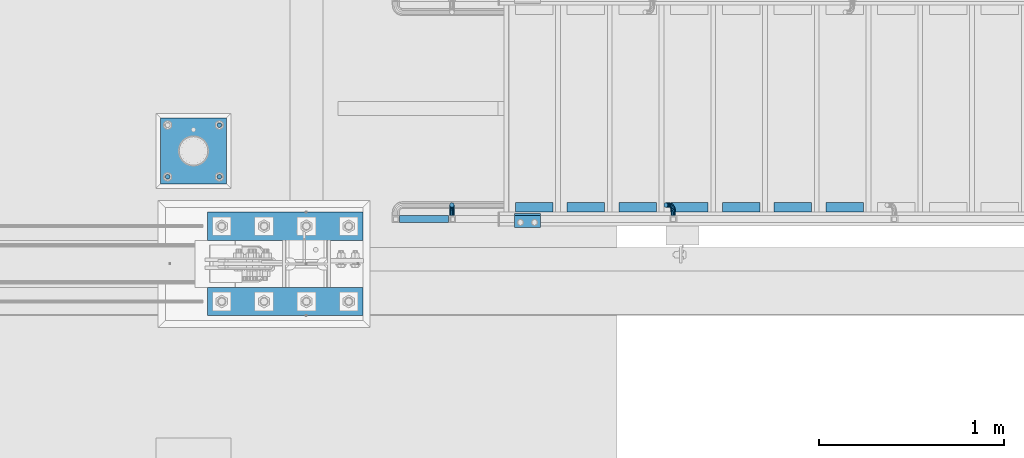
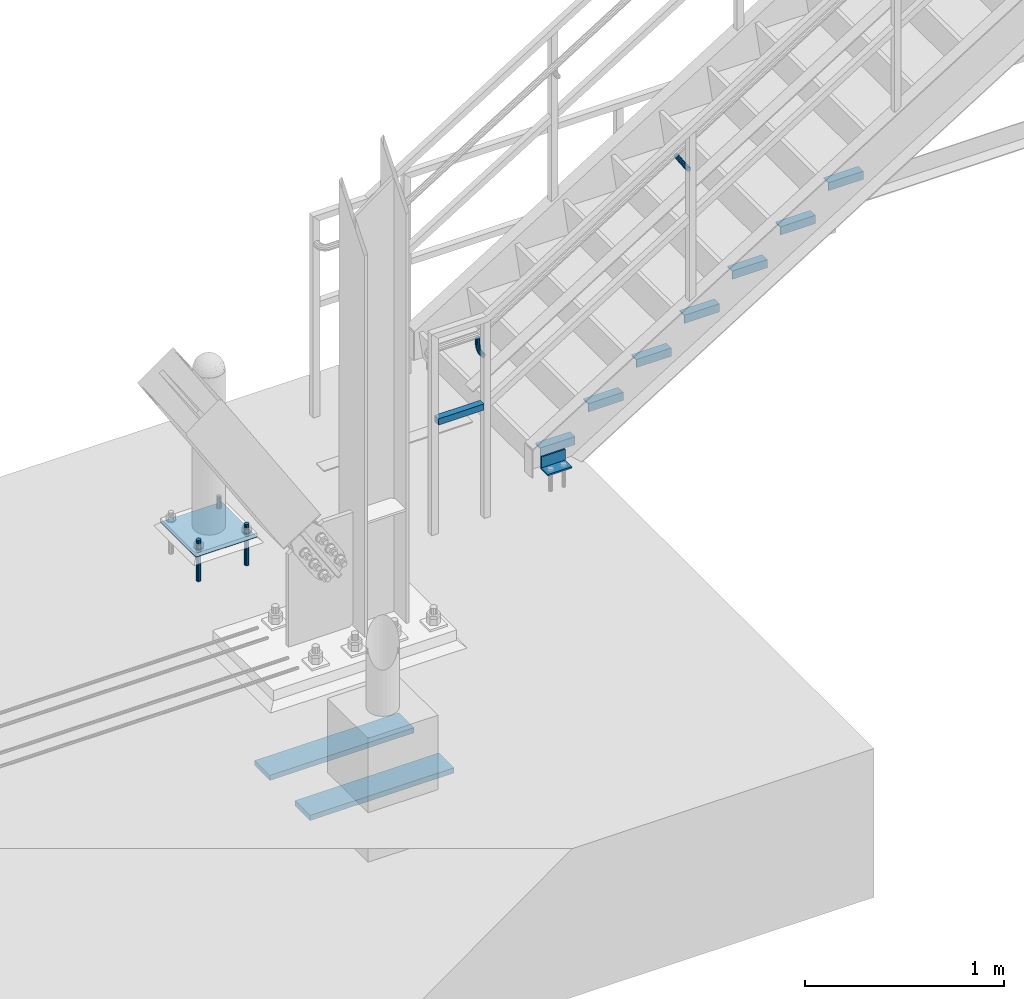
# One storey, part 2410 of 3843: 17 beams, 4 elements without a shape of their own.
"""IFC2X3 building model written with IfcOpenShell, lengths in millimetres."""

from ifc_helpers import new_model, si_unit, frame, origin_with_axes, place, context, subcontext, project, spatial, faceted_brep, material, type_object, element, aggregate, save


model = new_model("IFC2X3")

# Units and contexts
model_context = context("Model", 3, precision=1e-05, world=origin_with_axes())
body_context = subcontext(model_context, "Body", "Model", "MODEL_VIEW")
ifc_project = project(units=[si_unit("LENGTHUNIT", "METRE", prefix="MILLI"), si_unit("AREAUNIT", "SQUARE_METRE"), si_unit("VOLUMEUNIT", "CUBIC_METRE"), si_unit("MASSUNIT", "GRAM", prefix="KILO"), si_unit("TIMEUNIT", "SECOND"), si_unit("PLANEANGLEUNIT", "RADIAN"), si_unit("SOLIDANGLEUNIT", "STERADIAN"), si_unit("THERMODYNAMICTEMPERATUREUNIT", "DEGREE_CELSIUS"), si_unit("LUMINOUSINTENSITYUNIT", "LUMEN")], contexts=[model_context])

# Site, building, storey
site_placement = place(None, origin_with_axes())
site = spatial("IfcSite", under=ifc_project, at=site_placement, CompositionType="ELEMENT")
building_placement = place(site_placement, origin_with_axes())
building = spatial("IfcBuilding", under=site, at=building_placement, Name="Undefined", CompositionType="ELEMENT")
storey_placement = place(building_placement, origin_with_axes())
storey = spatial("IfcBuildingStorey", under=building, at=storey_placement, Name="Undefined", CompositionType="ELEMENT", Elevation=0.0)

# Assembly, beam
assembly_1_placement = place(storey_placement, origin_with_axes())
assembly_1 = element("IfcElementAssembly", 1, at=assembly_1_placement, inside=storey, Name="STAIR", AssemblyPlace="NOTDEFINED", PredefinedType="RIGID_FRAME")
ifc_material_1 = material(Name="STEEL/A572-50")
beam_type_1 = type_object("IfcBeamType", Name="L3X3X3/8", PredefinedType="NOTDEFINED")
beam_1_placement = place(assembly_1_placement, frame((31743.65, 89349.2625000009, 30518.1), z_axis=(0.0, -1.0, 0.0), x_axis=(-1.0, 0.0, 0.0)))
beam_1 = element("IfcBeam", 2, at=beam_1_placement, type_object=beam_type_1, material=ifc_material_1, Name="CLEAT", ObjectType="L3X3X3/8", context=body_context, shape_type="Brep", body=[
    faceted_brep([(0.0, 38.0999999999985, -38.0999999999985), (0.0, 38.0999999999985, 38.0999999999985), (139.699999999997, 38.0999999999985, 38.0999999999985), (139.699999999997, 38.0999999999985, -38.0999999999985), (0.0, 28.5750000000007, 38.0999999999985), (139.699999999997, 28.5750000000007, 38.0999999999985), (0.0, 28.5750000000007, -28.5750000000007), (139.699999999997, 28.5750000000007, -28.5750000000007), (0.0, -38.0999999999985, -28.5750000000007), (139.699999999997, -38.0999999999985, -28.5750000000007), (0.0, -38.0999999999985, -38.0999999999985), (139.699999999997, -38.0999999999985, -38.0999999999985)], [[[0, 1, 2, 3]], [[1, 4, 5, 2]], [[4, 6, 7, 5]], [[6, 8, 9, 7]], [[8, 10, 11, 9]], [[10, 0, 3, 11]], [[5, 7, 9, 11, 3, 2]], [[10, 8, 6, 4, 1, 0]]]),
])

# Assembly, beams
assembly_2_placement = place(storey_placement, origin_with_axes())
assembly_2 = element("IfcElementAssembly", 3, at=assembly_2_placement, inside=storey, Name="TEMPLATE", AssemblyPlace="NOTDEFINED", PredefinedType="RIGID_FRAME")
ifc_material_2 = material(Name="STEEL/316 SS")
beam_type_2 = type_object("IfcBeamType", PredefinedType="NOTDEFINED")
beam_2_placement = place(assembly_2_placement, frame((30010.1, 89585.8, 30581.6), z_axis=(1.0, 0.0, 0.0), x_axis=(0.0, 0.0, -1.0)))
beam_2 = element("IfcBeam", 4, at=beam_2_placement, type_object=beam_type_2, material=ifc_material_2, Name="ANCHOR_ROD", context=body_context, shape_type="Brep", body=[
    faceted_brep([(0.0, -12.6999999999971, 0.0), (0.0, -10.9985226280696, -6.34999999999854), (253.999, -10.9985226280696, -6.34999999999854), (253.999, -12.6999999999971, 0.0), (0.0, -6.35000000000582, -10.9985226280623), (253.999, -6.35000000000582, -10.9985226280623), (0.0, 0.0, -12.6999999999971), (253.999, 0.0, -12.6999999999971), (0.0, 6.35000000000582, -10.9985226280623), (253.999, 6.35000000000582, -10.9985226280623), (0.0, 10.9985226280696, -6.34999999999854), (253.999, 10.9985226280696, -6.34999999999854), (0.0, 12.6999999999971, 0.0), (253.999, 12.6999999999971, 0.0), (0.0, 10.9985226280696, 6.34999999999854), (253.999, 10.9985226280696, 6.34999999999854), (0.0, 6.35000000000582, 10.9985226280623), (253.999, 6.35000000000582, 10.9985226280623), (0.0, 0.0, 12.6999999999971), (253.999, 0.0, 12.6999999999971), (0.0, -6.35000000000582, 10.9985226280623), (253.999, -6.35000000000582, 10.9985226280623), (0.0, -10.9985226280696, 6.34999999999854), (253.999, -10.9985226280696, 6.34999999999854)], [[[0, 1, 2, 3]], [[1, 4, 5, 2]], [[4, 6, 7, 5]], [[6, 8, 9, 7]], [[8, 10, 11, 9]], [[10, 12, 13, 11]], [[12, 14, 15, 13]], [[14, 16, 17, 15]], [[16, 18, 19, 17]], [[18, 20, 21, 19]], [[20, 22, 23, 21]], [[22, 0, 3, 23]], [[5, 7, 9, 11, 13, 15, 17, 19, 21, 23, 3, 2]], [[22, 20, 18, 16, 14, 12, 10, 8, 6, 4, 1, 0]]]),
])
beam_3_placement = place(assembly_2_placement, frame((30010.1, 89865.2, 30581.6), z_axis=(-1.0, 0.0, 0.0), x_axis=(0.0, 0.0, -1.0)))
beam_3 = element("IfcBeam", 5, at=beam_3_placement, type_object=beam_type_2, material=ifc_material_2, Name="ANCHOR_ROD", context=body_context, shape_type="Brep", body=[
    faceted_brep([(0.0, -12.6999999999971, 0.0), (0.0, -10.9985226280696, -6.34999999999854), (253.999, -10.9985226280696, -6.34999999999854), (253.999, -12.6999999999971, 0.0), (0.0, -6.35000000000582, -10.9985226280623), (253.999, -6.35000000000582, -10.9985226280623), (0.0, 0.0, -12.6999999999971), (253.999, 0.0, -12.6999999999971), (0.0, 6.35000000000582, -10.9985226280623), (253.999, 6.35000000000582, -10.9985226280623), (0.0, 10.9985226280696, -6.34999999999854), (253.999, 10.9985226280696, -6.34999999999854), (0.0, 12.6999999999971, 0.0), (253.999, 12.6999999999971, 0.0), (0.0, 10.9985226280696, 6.34999999999854), (253.999, 10.9985226280696, 6.34999999999854), (0.0, 6.35000000000582, 10.9985226280623), (253.999, 6.35000000000582, 10.9985226280623), (0.0, 0.0, 12.6999999999971), (253.999, 0.0, 12.6999999999971), (0.0, -6.35000000000582, 10.9985226280623), (253.999, -6.35000000000582, 10.9985226280623), (0.0, -10.9985226280696, 6.34999999999854), (253.999, -10.9985226280696, 6.34999999999854)], [[[0, 1, 2, 3]], [[1, 4, 5, 2]], [[4, 6, 7, 5]], [[6, 8, 9, 7]], [[8, 10, 11, 9]], [[10, 12, 13, 11]], [[12, 14, 15, 13]], [[14, 16, 17, 15]], [[16, 18, 19, 17]], [[18, 20, 21, 19]], [[20, 22, 23, 21]], [[22, 0, 3, 23]], [[5, 7, 9, 11, 13, 15, 17, 19, 21, 23, 3, 2]], [[22, 20, 18, 16, 14, 12, 10, 8, 6, 4, 1, 0]]]),
])
beam_4_placement = place(assembly_2_placement, frame((29730.7, 89585.8, 30581.6), z_axis=(1.0, 0.0, 0.0), x_axis=(0.0, 0.0, -1.0)))
beam_4 = element("IfcBeam", 6, at=beam_4_placement, type_object=beam_type_2, material=ifc_material_2, Name="ANCHOR_ROD", context=body_context, shape_type="Brep", body=[
    faceted_brep([(0.0, -12.6999999999971, 0.0), (0.0, -10.9985226280696, -6.34999999999854), (253.999, -10.9985226280696, -6.34999999999854), (253.999, -12.6999999999971, 0.0), (0.0, -6.35000000000582, -10.9985226280623), (253.999, -6.35000000000582, -10.9985226280623), (0.0, 0.0, -12.6999999999971), (253.999, 0.0, -12.6999999999971), (0.0, 6.35000000000582, -10.9985226280623), (253.999, 6.35000000000582, -10.9985226280623), (0.0, 10.9985226280696, -6.34999999999854), (253.999, 10.9985226280696, -6.34999999999854), (0.0, 12.6999999999971, 0.0), (253.999, 12.6999999999971, 0.0), (0.0, 10.9985226280696, 6.34999999999854), (253.999, 10.9985226280696, 6.34999999999854), (0.0, 6.35000000000582, 10.9985226280623), (253.999, 6.35000000000582, 10.9985226280623), (0.0, 0.0, 12.6999999999971), (253.999, 0.0, 12.6999999999971), (0.0, -6.35000000000582, 10.9985226280623), (253.999, -6.35000000000582, 10.9985226280623), (0.0, -10.9985226280696, 6.34999999999854), (253.999, -10.9985226280696, 6.34999999999854)], [[[0, 1, 2, 3]], [[1, 4, 5, 2]], [[4, 6, 7, 5]], [[6, 8, 9, 7]], [[8, 10, 11, 9]], [[10, 12, 13, 11]], [[12, 14, 15, 13]], [[14, 16, 17, 15]], [[16, 18, 19, 17]], [[18, 20, 21, 19]], [[20, 22, 23, 21]], [[22, 0, 3, 23]], [[5, 7, 9, 11, 13, 15, 17, 19, 21, 23, 3, 2]], [[22, 20, 18, 16, 14, 12, 10, 8, 6, 4, 1, 0]]]),
])
ifc_material_3 = material(Name="STEEL/A36")
beam_type_3 = type_object("IfcBeamType", PredefinedType="NOTDEFINED")
beam_5_placement = place(assembly_2_placement, frame((30048.2, 89725.5, 30506.9875), z_axis=(0.0, -1.0, 0.0), x_axis=(-1.0, 0.0, 0.0)))
beam_5 = element("IfcBeam", 7, at=beam_5_placement, type_object=beam_type_3, material=ifc_material_3, Name="TEMPLATE", context=body_context, shape_type="Brep", body=[
    faceted_brep([(0.0, 1.58750000000146, -177.800000000003), (0.0, 1.58750000000146, 177.800000000003), (355.600000000006, 1.58750000000146, 177.800000000003), (355.600000000006, 1.58750000000146, -177.800000000003), (0.0, -1.58750000000146, 177.800000000003), (355.600000000006, -1.58750000000146, 177.800000000003), (0.0, -1.58750000000146, -177.800000000003), (355.600000000006, -1.58750000000146, -177.800000000003)], [[[0, 1, 2, 3]], [[1, 4, 5, 2]], [[4, 6, 7, 5]], [[6, 0, 3, 7]], [[5, 7, 3, 2]], [[6, 4, 1, 0]]]),
])
aggregate(assembly_2, [beam_2, beam_3, beam_4, beam_5])

# Assembly, beam
assembly_3_placement = place(storey_placement, origin_with_axes())
assembly_3 = element("IfcElementAssembly", 8, at=assembly_3_placement, inside=storey, Name="RAIL", AssemblyPlace="NOTDEFINED", PredefinedType="RIGID_FRAME")
ifc_material_4 = material()
beam_type_4 = type_object("IfcBeamType", Name="HSS1-1/2X1-1/2X1/4", PredefinedType="NOTDEFINED")
beam_6_placement = place(assembly_3_placement, frame((30962.6000000001, 89357.2000000455, 31013.4), z_axis=(0.0, 0.0, 1.0), x_axis=(1.0, 0.0, 0.0)))
beam_6 = element("IfcBeam", 9, at=beam_6_placement, type_object=beam_type_4, material=ifc_material_4, Name="RAIL", ObjectType="HSS1-1/2X1-1/2X1/4", context=body_context, shape_type="Brep", body=[
    faceted_brep([(285.750000765285, -19.0499992350015, 19.0499992350015), (285.750000765285, -19.0499992350015, -19.0499992350015), (285.750000765285, 19.0499992350015, -19.0499992350015), (285.750000765285, 19.0499992350015, 19.0499992350015), (285.750000765009, -12.6999993300014, 12.6999993299978), (285.750000765009, 12.6999993300014, 12.6999993299978), (285.750000765009, 12.6999993300014, -12.6999993299978), (285.750000765009, -12.6999993300014, -12.6999993299978), (19.0499992350015, 19.0499992350015, -19.0499992350015), (19.0499992350015, 19.0499992350015, 19.0499992350015), (19.0499992350015, -19.0499992350015, 19.0499992350015), (19.0499992350015, -19.0499992350015, -19.0499992350015), (19.0499992350015, 12.6999993299978, 12.6999993299978), (19.0499992350015, -12.6999993299978, 12.6999993299978), (19.0499992350015, -12.6999993299978, -12.6999993299978), (19.0499992350015, 12.6999993299978, -12.6999993299978)], [[[0, 1, 2, 3], [4, 5, 6, 7]], [[8, 9, 3, 2]], [[9, 10, 0, 3]], [[10, 11, 1, 0]], [[11, 8, 2, 1]], [[11, 10, 9, 8], [12, 13, 14, 15]], [[14, 13, 4, 7]], [[15, 14, 7, 6]], [[12, 15, 6, 5]], [[13, 12, 5, 4]]]),
])

# Beam
beam_type_5 = type_object("IfcBeamType", Name="L2X2X3/16", PredefinedType="NOTDEFINED")
beam_7_placement = place(assembly_1_placement, frame((33487.8169176732, 89420.7000000434, 31619.8250000043), z_axis=(0.0, 1.0, 0.0), x_axis=(-1.0, 0.0, 0.0)))
beam_7 = element("IfcBeam", 10, at=beam_7_placement, type_object=beam_type_5, material=ifc_material_3, Name="ANGLE", ObjectType="L2X2X3/16", context=body_context, shape_type="Brep", body=[
    faceted_brep([(0.0, 25.4000000000015, -25.4000000000015), (0.0, 25.4000000000015, 25.4000000000015), (203.199999999997, 25.4000000000015, 25.4000000000015), (203.199999999997, 25.4000000000015, -25.4000000000015), (0.0, 20.6375000000007, 25.4000000000015), (203.199999999997, 20.6375000000007, 25.4000000000015), (0.0, 20.6375000000007, -20.6375000000007), (203.199999999997, 20.6375000000007, -20.6375000000007), (0.0, -25.4000000000015, -20.6375000000007), (203.199999999997, -25.4000000000015, -20.6375000000007), (0.0, -25.4000000000015, -25.4000000000015), (203.199999999997, -25.4000000000015, -25.4000000000015)], [[[0, 1, 2, 3]], [[1, 4, 5, 2]], [[4, 6, 7, 5]], [[6, 8, 9, 7]], [[8, 10, 11, 9]], [[10, 0, 3, 11]], [[5, 7, 9, 11, 3, 2]], [[10, 8, 6, 4, 1, 0]]]),
])

beam_8_placement = place(assembly_1_placement, frame((33208.4169176732, 89420.7000000434, 31445.6535714329), z_axis=(0.0, 1.0, 0.0), x_axis=(-1.0, 0.0, 0.0)))
beam_8 = element("IfcBeam", 11, at=beam_8_placement, type_object=beam_type_5, material=ifc_material_3, Name="ANGLE", ObjectType="L2X2X3/16", context=body_context, shape_type="Brep", body=[
    faceted_brep([(0.0, 25.4000000000015, -25.4000000000015), (0.0, 25.4000000000015, 25.4000000000015), (203.199999999997, 25.4000000000015, 25.4000000000015), (203.199999999997, 25.4000000000015, -25.4000000000015), (0.0, 20.6375000000007, 25.4000000000015), (203.199999999997, 20.6375000000007, 25.4000000000015), (0.0, 20.6375000000007, -20.6375000000007), (203.199999999997, 20.6375000000007, -20.6375000000007), (0.0, -25.4000000000015, -20.6375000000007), (203.199999999997, -25.4000000000015, -20.6375000000007), (0.0, -25.4000000000015, -25.4000000000015), (203.199999999997, -25.4000000000015, -25.4000000000015)], [[[0, 1, 2, 3]], [[1, 4, 5, 2]], [[4, 6, 7, 5]], [[6, 8, 9, 7]], [[8, 10, 11, 9]], [[10, 0, 3, 11]], [[5, 7, 9, 11, 3, 2]], [[10, 8, 6, 4, 1, 0]]]),
])

beam_9_placement = place(assembly_1_placement, frame((32929.0169176732, 89420.7000000434, 31271.4821428615), z_axis=(0.0, 1.0, 0.0), x_axis=(-1.0, 0.0, 0.0)))
beam_9 = element("IfcBeam", 12, at=beam_9_placement, type_object=beam_type_5, material=ifc_material_3, Name="ANGLE", ObjectType="L2X2X3/16", context=body_context, shape_type="Brep", body=[
    faceted_brep([(0.0, 25.4000000000015, -25.4000000000015), (0.0, 25.4000000000015, 25.4000000000015), (203.199999999997, 25.4000000000015, 25.4000000000015), (203.199999999997, 25.4000000000015, -25.4000000000015), (0.0, 20.6375000000007, 25.4000000000015), (203.199999999997, 20.6375000000007, 25.4000000000015), (0.0, 20.6375000000007, -20.6375000000007), (203.199999999997, 20.6375000000007, -20.6375000000007), (0.0, -25.4000000000015, -20.6375000000007), (203.199999999997, -25.4000000000015, -20.6375000000007), (0.0, -25.4000000000015, -25.4000000000015), (203.199999999997, -25.4000000000015, -25.4000000000015)], [[[0, 1, 2, 3]], [[1, 4, 5, 2]], [[4, 6, 7, 5]], [[6, 8, 9, 7]], [[8, 10, 11, 9]], [[10, 0, 3, 11]], [[5, 7, 9, 11, 3, 2]], [[10, 8, 6, 4, 1, 0]]]),
])

beam_10_placement = place(assembly_1_placement, frame((32649.6169176732, 89420.7000000434, 31097.31071429), z_axis=(0.0, 1.0, 0.0), x_axis=(-1.0, 0.0, 0.0)))
beam_10 = element("IfcBeam", 13, at=beam_10_placement, type_object=beam_type_5, material=ifc_material_3, Name="ANGLE", ObjectType="L2X2X3/16", context=body_context, shape_type="Brep", body=[
    faceted_brep([(0.0, 25.4000000000015, -25.4000000000015), (0.0, 25.4000000000015, 25.4000000000015), (203.199999999997, 25.4000000000015, 25.4000000000015), (203.199999999997, 25.4000000000015, -25.4000000000015), (0.0, 20.6375000000007, 25.4000000000015), (203.199999999997, 20.6375000000007, 25.4000000000015), (0.0, 20.6375000000007, -20.6375000000007), (203.199999999997, 20.6375000000007, -20.6375000000007), (0.0, -25.4000000000015, -20.6375000000007), (203.199999999997, -25.4000000000015, -20.6375000000007), (0.0, -25.4000000000015, -25.4000000000015), (203.199999999997, -25.4000000000015, -25.4000000000015)], [[[0, 1, 2, 3]], [[1, 4, 5, 2]], [[4, 6, 7, 5]], [[6, 8, 9, 7]], [[8, 10, 11, 9]], [[10, 0, 3, 11]], [[5, 7, 9, 11, 3, 2]], [[10, 8, 6, 4, 1, 0]]]),
])

beam_11_placement = place(assembly_1_placement, frame((32370.2169176732, 89420.7000000434, 30923.1392857186), z_axis=(0.0, 1.0, 0.0), x_axis=(-1.0, 0.0, 0.0)))
beam_11 = element("IfcBeam", 14, at=beam_11_placement, type_object=beam_type_5, material=ifc_material_3, Name="ANGLE", ObjectType="L2X2X3/16", context=body_context, shape_type="Brep", body=[
    faceted_brep([(0.0, 25.4000000000015, -25.4000000000015), (0.0, 25.4000000000015, 25.4000000000015), (203.199999999997, 25.4000000000015, 25.4000000000015), (203.199999999997, 25.4000000000015, -25.4000000000015), (0.0, 20.6375000000007, 25.4000000000015), (203.199999999997, 20.6375000000007, 25.4000000000015), (0.0, 20.6375000000007, -20.6375000000007), (203.199999999997, 20.6375000000007, -20.6375000000007), (0.0, -25.4000000000015, -20.6375000000007), (203.199999999997, -25.4000000000015, -20.6375000000007), (0.0, -25.4000000000015, -25.4000000000015), (203.199999999997, -25.4000000000015, -25.4000000000015)], [[[0, 1, 2, 3]], [[1, 4, 5, 2]], [[4, 6, 7, 5]], [[6, 8, 9, 7]], [[8, 10, 11, 9]], [[10, 0, 3, 11]], [[5, 7, 9, 11, 3, 2]], [[10, 8, 6, 4, 1, 0]]]),
])

beam_12_placement = place(assembly_1_placement, frame((32090.8169176732, 89420.7000000434, 30748.9678571472), z_axis=(0.0, 1.0, 0.0), x_axis=(-1.0, 0.0, 0.0)))
beam_12 = element("IfcBeam", 15, at=beam_12_placement, type_object=beam_type_5, material=ifc_material_3, Name="ANGLE", ObjectType="L2X2X3/16", context=body_context, shape_type="Brep", body=[
    faceted_brep([(0.0, 25.4000000000015, -25.4000000000015), (0.0, 25.4000000000015, 25.4000000000015), (203.199999999997, 25.4000000000015, 25.4000000000015), (203.199999999997, 25.4000000000015, -25.4000000000015), (0.0, 20.6375000000007, 25.4000000000015), (203.199999999997, 20.6375000000007, 25.4000000000015), (0.0, 20.6375000000007, -20.6375000000007), (203.199999999997, 20.6375000000007, -20.6375000000007), (0.0, -25.4000000000015, -20.6375000000007), (203.199999999997, -25.4000000000015, -20.6375000000007), (0.0, -25.4000000000015, -25.4000000000015), (203.199999999997, -25.4000000000015, -25.4000000000015)], [[[0, 1, 2, 3]], [[1, 4, 5, 2]], [[4, 6, 7, 5]], [[6, 8, 9, 7]], [[8, 10, 11, 9]], [[10, 0, 3, 11]], [[5, 7, 9, 11, 3, 2]], [[10, 8, 6, 4, 1, 0]]]),
])

beam_13_placement = place(assembly_1_placement, frame((31811.4169176732, 89420.7000000434, 30574.7964285758), z_axis=(0.0, 1.0, 0.0), x_axis=(-1.0, 0.0, 0.0)))
beam_13 = element("IfcBeam", 16, at=beam_13_placement, type_object=beam_type_5, material=ifc_material_3, Name="ANGLE", ObjectType="L2X2X3/16", context=body_context, shape_type="Brep", body=[
    faceted_brep([(0.0, 25.4000000000015, -25.4000000000015), (0.0, 25.4000000000015, 25.4000000000015), (203.199999999997, 25.4000000000015, 25.4000000000015), (203.199999999997, 25.4000000000015, -25.4000000000015), (0.0, 20.6375000000007, 25.4000000000015), (203.199999999997, 20.6375000000007, 25.4000000000015), (0.0, 20.6375000000007, -20.6375000000007), (203.199999999997, 20.6375000000007, -20.6375000000007), (0.0, -25.4000000000015, -20.6375000000007), (203.199999999997, -25.4000000000015, -20.6375000000007), (0.0, -25.4000000000015, -25.4000000000015), (203.199999999997, -25.4000000000015, -25.4000000000015)], [[[0, 1, 2, 3]], [[1, 4, 5, 2]], [[4, 6, 7, 5]], [[6, 8, 9, 7]], [[8, 10, 11, 9]], [[10, 0, 3, 11]], [[5, 7, 9, 11, 3, 2]], [[10, 8, 6, 4, 1, 0]]]),
])

aggregate(assembly_1, [beam_1, beam_7, beam_8, beam_9, beam_10, beam_11, beam_12, beam_13])

beam_type_6 = type_object("IfcBeamType", PredefinedType="NOTDEFINED")
beam_14_placement = place(assembly_3_placement, frame((32461.5432322763, 89376.2500000455, 32026.5595126729), z_axis=(0.848616882600527, 0.0, 0.529007926750974), x_axis=(0.0, 1.0, 0.0)))
beam_14 = element("IfcBeam", 17, at=beam_14_placement, type_object=beam_type_6, material=ifc_material_3, Name="BRACKET ARM", context=body_context, shape_type="Brep", body=[
    faceted_brep([(0.0, -12.6999999999971, 0.0), (0.0, -10.9985226280696, -6.34999999999854), (19.0500015258731, -10.9985226280623, -6.34999999999854), (19.0500015258731, -12.6999999999971, -6.33008312433958e-10), (0.0, -6.35000000000582, -10.9985226280623), (19.0500015258731, -6.34999999999854, -10.9985226280623), (0.0, 0.0, -12.6999999999971), (19.0500015258731, 0.0, -12.6999999999971), (0.0, 6.35000000000582, -10.9985226280623), (19.0500015258731, 6.34999999999854, -10.9985226280623), (0.0, 10.9985226280696, -6.34999999999854), (19.0500015258731, 10.9985226280623, -6.34999999999854), (0.0, 12.6999999999971, 0.0), (19.0500015258731, 12.6999999999971, 0.0), (0.0, 10.9985226280696, 6.34999999999854), (19.0500015258731, 10.9985226280623, 6.34999999999854), (0.0, 6.35000000000582, 10.9985226280623), (19.0500015258731, 6.34999999999854, 10.9985226280623), (0.0, 0.0, 12.6999999999971), (19.0500015258731, 0.0, 12.6999999999971), (0.0, -6.35000000000582, 10.9985226280623), (19.0500015258731, -6.34999999999854, 10.9985226280623), (0.0, -10.9985226280696, 6.34999999999854), (19.0500015258731, -10.9985226280623, 6.34999999999854), (38.4903193060891, -8.8330803677236, -3.34694050252438e-10), (37.8391921052389, -7.26112024908798, 6.34999999974389), (36.0602795104642, -2.96644533684594, 10.9985226280041), (33.6302397149266, 2.90018969451194, 12.7000000002226), (31.2001999194181, 8.76682472604443, 10.9985226285644), (29.4212873247307, 13.061499638774, 6.35000000070431), (28.7701601240115, 14.6334597580644, 7.78527464717627e-10), (29.4212873248762, 13.0614996394288, -6.34999999929278), (31.2001999196509, 8.76682472718676, -10.9985226275603), (33.6302397151885, 2.90018969582889, -12.6999999997788), (36.0602795106824, -2.96644533571089, -10.9985226281206), (37.8391921053699, -7.26112024843314, -6.35000000026048), (53.7678987435793, 3.38210125690239, -6.3499999994383), (54.9710249311902, 2.17897506880399, 5.0931703299284e-10), (50.4808968708676, 6.66910312997061, -10.9985226273784), (45.9907688103704, 11.1592311906061, -12.6999999991458), (41.5006407498004, 15.6493592510378, -10.9985226270364), (38.213638876914, 18.9363611235749, -6.34999999884167), (37.0105126890558, 20.1394873109457, 1.20053300634027e-09), (38.2136388766667, 18.9363611228473, 6.35000000115542), (41.5006407493784, 15.6493592497718, 10.9985226290883), (45.9907688098756, 11.1592311891436, 12.7000000008557), (50.4808968704456, 6.66910312870459, 10.9985226287463), (53.7678987433319, 3.38210125617479, 6.35000000055879), (64.4111202489148, 19.3108078951118, -6.34999999821594), (65.9830803677178, 18.6596806939051, 1.77533365786076e-09), (60.1164453365491, 21.0897204901557, -10.9985226262725), (54.2498103051475, 23.5197602857806, -12.6999999981927), (48.3831752736587, 25.9498000811873, -10.9985226262434), (44.0885003610601, 27.7287126756128, -6.34999999817228), (42.516540241937, 28.3798398759754, 1.83354131877422e-09), (44.08850036074, 27.7287126747688, 6.35000000183209), (48.3831752731057, 25.9498000797321, 10.9985226298813), (54.2498103045073, 23.5197602840999, 12.7000000018088), (60.1164453359961, 21.0897204886933, 10.9985226298522), (64.4111202485947, 19.3108078942678, 6.35000000178115), (68.1485226282239, 38.0999984746086, -6.3499999967753), (69.8499999999913, 38.0999984741211, 2.92493496090174e-09), (63.500000000291, 38.0999984749651, -10.9985226249628), (57.1500000003434, 38.0999984750961, -12.6999999970722), (50.8000000002939, 38.0999984749651, -10.998522625312), (46.1514773720992, 38.0999984746086, -6.34999999737192), (44.4499999999971, 38.0999984741211, 2.58296495303512e-09), (46.1514773717645, 38.0999984736336, 6.35000000262517), (50.7999999996973, 38.0999984732771, 10.9985226308127), (57.1499999996449, 38.0999984731461, 12.700000002922), (63.4999999996944, 38.0999984732771, 10.9985226311619), (68.1485226278892, 38.0999984736336, 6.35000000322179), (68.1485226280638, 76.2000000002372, -6.34999999414867), (69.8499999999913, 76.199999999757, 5.84986992180347e-09), (63.5, 76.200000000601, -10.9985226222125), (57.1499999999942, 76.2000000007247, -12.6999999941472), (50.7999999999884, 76.200000000601, -10.9985226222125), (46.1514773719246, 76.2000000002372, -6.34999999414867), (44.4499999999971, 76.199999999757, 5.84986992180347e-09), (46.1514773719246, 76.1999999992695, 6.35000000584841), (50.7999999999884, 76.1999999989057, 10.9985226339122), (57.1499999999942, 76.199999998782, 12.700000005847), (63.5, 76.1999999989057, 10.9985226339122), (68.1485226280638, 76.1999999992695, 6.35000000584841)], [[[0, 1, 2, 3]], [[1, 4, 5, 2]], [[4, 6, 7, 5]], [[6, 8, 9, 7]], [[8, 10, 11, 9]], [[10, 12, 13, 11]], [[12, 14, 15, 13]], [[14, 16, 17, 15]], [[16, 18, 19, 17]], [[18, 20, 21, 19]], [[20, 22, 23, 21]], [[22, 0, 3, 23]], [[22, 20, 18, 16, 14, 12, 10, 8, 6, 4, 1, 0]], [[23, 3, 24, 25]], [[21, 23, 25, 26]], [[19, 21, 26, 27]], [[17, 19, 27, 28]], [[15, 17, 28, 29]], [[13, 15, 29, 30]], [[11, 13, 30, 31]], [[9, 11, 31, 32]], [[7, 9, 32, 33]], [[5, 7, 33, 34]], [[2, 5, 34, 35]], [[3, 2, 35, 24]], [[35, 36, 37, 24]], [[34, 38, 36, 35]], [[33, 39, 38, 34]], [[32, 40, 39, 33]], [[31, 41, 40, 32]], [[30, 42, 41, 31]], [[29, 43, 42, 30]], [[28, 44, 43, 29]], [[27, 45, 44, 28]], [[26, 46, 45, 27]], [[25, 47, 46, 26]], [[24, 37, 47, 25]], [[36, 48, 49, 37]], [[38, 50, 48, 36]], [[39, 51, 50, 38]], [[40, 52, 51, 39]], [[41, 53, 52, 40]], [[42, 54, 53, 41]], [[43, 55, 54, 42]], [[44, 56, 55, 43]], [[45, 57, 56, 44]], [[46, 58, 57, 45]], [[47, 59, 58, 46]], [[37, 49, 59, 47]], [[48, 60, 61, 49]], [[50, 62, 60, 48]], [[51, 63, 62, 50]], [[52, 64, 63, 51]], [[53, 65, 64, 52]], [[54, 66, 65, 53]], [[55, 67, 66, 54]], [[56, 68, 67, 55]], [[57, 69, 68, 56]], [[58, 70, 69, 57]], [[59, 71, 70, 58]], [[49, 61, 71, 59]], [[61, 60, 72, 73]], [[60, 62, 74, 72]], [[62, 63, 75, 74]], [[63, 64, 76, 75]], [[64, 65, 77, 76]], [[65, 66, 78, 77]], [[66, 67, 79, 78]], [[67, 68, 80, 79]], [[68, 69, 81, 80]], [[69, 70, 82, 81]], [[70, 71, 83, 82]], [[71, 61, 73, 83]], [[74, 75, 76, 77, 78, 79, 80, 81, 82, 83, 73, 72]]]),
])

beam_15_placement = place(assembly_3_placement, frame((31265.8125005141, 89376.2500000455, 31299.1499998101), z_axis=(1.0, 0.0, 0.0), x_axis=(0.0, 1.0, 0.0)))
beam_15 = element("IfcBeam", 18, at=beam_15_placement, type_object=beam_type_6, material=ifc_material_3, Name="BRACKET ARM", context=body_context, shape_type="Brep", body=[
    faceted_brep([(0.0, -12.6999999999971, 0.0), (0.0, -10.9985226280696, -6.34999999999854), (19.0500015258731, -10.9985226280623, -6.34999999999854), (19.0500015258731, -12.6999999999971, -6.33008312433958e-10), (0.0, -6.35000000000582, -10.9985226280623), (19.0500015258731, -6.34999999999854, -10.9985226280623), (0.0, 0.0, -12.6999999999971), (19.0500015258731, 0.0, -12.6999999999971), (0.0, 6.35000000000582, -10.9985226280623), (19.0500015258731, 6.34999999999854, -10.9985226280623), (0.0, 10.9985226280696, -6.34999999999854), (19.0500015258731, 10.9985226280623, -6.34999999999854), (0.0, 12.6999999999971, 0.0), (19.0500015258731, 12.6999999999971, 0.0), (0.0, 10.9985226280696, 6.34999999999854), (19.0500015258731, 10.9985226280623, 6.34999999999854), (0.0, 6.35000000000582, 10.9985226280623), (19.0500015258731, 6.34999999999854, 10.9985226280623), (0.0, 0.0, 12.6999999999971), (19.0500015258731, 0.0, 12.6999999999971), (0.0, -6.35000000000582, 10.9985226280623), (19.0500015258731, -6.34999999999854, 10.9985226280623), (0.0, -10.9985226280696, 6.34999999999854), (19.0500015258731, -10.9985226280623, 6.34999999999854), (38.4903193060891, -8.8330803677236, -3.34694050252438e-10), (37.8391921052389, -7.26112024908798, 6.34999999974389), (36.0602795104642, -2.96644533684594, 10.9985226280041), (33.6302397149266, 2.90018969451194, 12.7000000002226), (31.2001999194181, 8.76682472604443, 10.9985226285644), (29.4212873247307, 13.061499638774, 6.35000000070431), (28.7701601240115, 14.6334597580644, 7.78527464717627e-10), (29.4212873248762, 13.0614996394288, -6.34999999929278), (31.2001999196509, 8.76682472718676, -10.9985226275603), (33.6302397151885, 2.90018969582889, -12.6999999997788), (36.0602795106824, -2.96644533571089, -10.9985226281206), (37.8391921053699, -7.26112024843314, -6.35000000026048), (53.7678987435793, 3.38210125690239, -6.3499999994383), (54.9710249311902, 2.17897506880399, 5.0931703299284e-10), (50.4808968708676, 6.66910312997061, -10.9985226273784), (45.9907688103704, 11.1592311906061, -12.6999999991458), (41.5006407498004, 15.6493592510378, -10.9985226270364), (38.213638876914, 18.9363611235749, -6.34999999884167), (37.0105126890558, 20.1394873109457, 1.20053300634027e-09), (38.2136388766667, 18.9363611228473, 6.35000000115542), (41.5006407493784, 15.6493592497718, 10.9985226290883), (45.9907688098756, 11.1592311891436, 12.7000000008557), (50.4808968704456, 6.66910312870459, 10.9985226287463), (53.7678987433319, 3.38210125617479, 6.35000000055879), (64.4111202489148, 19.3108078951118, -6.34999999821594), (65.9830803677178, 18.6596806939051, 1.77533365786076e-09), (60.1164453365491, 21.0897204901557, -10.9985226262725), (54.2498103051475, 23.5197602857806, -12.6999999981927), (48.3831752736587, 25.9498000811873, -10.9985226262434), (44.0885003610601, 27.7287126756128, -6.34999999817228), (42.516540241937, 28.3798398759754, 1.83354131877422e-09), (44.08850036074, 27.7287126747688, 6.35000000183209), (48.3831752731057, 25.9498000797321, 10.9985226298813), (54.2498103045073, 23.5197602840999, 12.7000000018088), (60.1164453359961, 21.0897204886933, 10.9985226298522), (64.4111202485947, 19.3108078942678, 6.35000000178115), (68.1485226282239, 38.0999984746086, -6.3499999967753), (69.8499999999913, 38.0999984741211, 2.92493496090174e-09), (63.500000000291, 38.0999984749651, -10.9985226249628), (57.1500000003434, 38.0999984750961, -12.6999999970722), (50.8000000002939, 38.0999984749651, -10.998522625312), (46.1514773720992, 38.0999984746086, -6.34999999737192), (44.4499999999971, 38.0999984741211, 2.58296495303512e-09), (46.1514773717645, 38.0999984736336, 6.35000000262517), (50.7999999996973, 38.0999984732771, 10.9985226308127), (57.1499999996449, 38.0999984731461, 12.700000002922), (63.4999999996944, 38.0999984732771, 10.9985226311619), (68.1485226278892, 38.0999984736336, 6.35000000322179), (68.1485226280638, 76.2000000002372, -6.34999999414867), (69.8499999999913, 76.199999999757, 5.84986992180347e-09), (63.5, 76.200000000601, -10.9985226222125), (57.1499999999942, 76.2000000007247, -12.6999999941472), (50.7999999999884, 76.200000000601, -10.9985226222125), (46.1514773719246, 76.2000000002372, -6.34999999414867), (44.4499999999971, 76.199999999757, 5.84986992180347e-09), (46.1514773719246, 76.1999999992695, 6.35000000584841), (50.7999999999884, 76.1999999989057, 10.9985226339122), (57.1499999999942, 76.199999998782, 12.700000005847), (63.5, 76.1999999989057, 10.9985226339122), (68.1485226280638, 76.1999999992695, 6.35000000584841)], [[[0, 1, 2, 3]], [[1, 4, 5, 2]], [[4, 6, 7, 5]], [[6, 8, 9, 7]], [[8, 10, 11, 9]], [[10, 12, 13, 11]], [[12, 14, 15, 13]], [[14, 16, 17, 15]], [[16, 18, 19, 17]], [[18, 20, 21, 19]], [[20, 22, 23, 21]], [[22, 0, 3, 23]], [[22, 20, 18, 16, 14, 12, 10, 8, 6, 4, 1, 0]], [[23, 3, 24, 25]], [[21, 23, 25, 26]], [[19, 21, 26, 27]], [[17, 19, 27, 28]], [[15, 17, 28, 29]], [[13, 15, 29, 30]], [[11, 13, 30, 31]], [[9, 11, 31, 32]], [[7, 9, 32, 33]], [[5, 7, 33, 34]], [[2, 5, 34, 35]], [[3, 2, 35, 24]], [[35, 36, 37, 24]], [[34, 38, 36, 35]], [[33, 39, 38, 34]], [[32, 40, 39, 33]], [[31, 41, 40, 32]], [[30, 42, 41, 31]], [[29, 43, 42, 30]], [[28, 44, 43, 29]], [[27, 45, 44, 28]], [[26, 46, 45, 27]], [[25, 47, 46, 26]], [[24, 37, 47, 25]], [[36, 48, 49, 37]], [[38, 50, 48, 36]], [[39, 51, 50, 38]], [[40, 52, 51, 39]], [[41, 53, 52, 40]], [[42, 54, 53, 41]], [[43, 55, 54, 42]], [[44, 56, 55, 43]], [[45, 57, 56, 44]], [[46, 58, 57, 45]], [[47, 59, 58, 46]], [[37, 49, 59, 47]], [[48, 60, 61, 49]], [[50, 62, 60, 48]], [[51, 63, 62, 50]], [[52, 64, 63, 51]], [[53, 65, 64, 52]], [[54, 66, 65, 53]], [[55, 67, 66, 54]], [[56, 68, 67, 55]], [[57, 69, 68, 56]], [[58, 70, 69, 57]], [[59, 71, 70, 58]], [[49, 61, 71, 59]], [[61, 60, 72, 73]], [[60, 62, 74, 72]], [[62, 63, 75, 74]], [[63, 64, 76, 75]], [[64, 65, 77, 76]], [[65, 66, 78, 77]], [[66, 67, 79, 78]], [[67, 68, 80, 79]], [[68, 69, 81, 80]], [[69, 70, 82, 81]], [[70, 71, 83, 82]], [[71, 61, 73, 83]], [[74, 75, 76, 77, 78, 79, 80, 81, 82, 83, 73, 72]]]),
])

aggregate(assembly_3, [beam_14, beam_15, beam_6])

# Assembly, beams
assembly_4_placement = place(storey_placement, origin_with_axes())
assembly_4 = element("IfcElementAssembly", 19, at=assembly_4_placement, inside=storey, Name="TEMPLATE", AssemblyPlace="NOTDEFINED", PredefinedType="RIGID_FRAME")
beam_type_7 = type_object("IfcBeamType", PredefinedType="NOTDEFINED")
beam_16_placement = place(assembly_4_placement, frame((30784.8, 88912.7, 29244.925), z_axis=(0.0, 1.0, 0.0), x_axis=(-1.0, 0.0, 0.0)))
beam_16 = element("IfcBeam", 20, at=beam_16_placement, type_object=beam_type_7, material=ifc_material_1, context=body_context, shape_type="Brep", body=[
    faceted_brep([(0.0, 15.875, -76.1999999999971), (0.0, 15.875, 76.1999999999971), (838.199999999997, 15.875, 76.1999999999971), (838.199999999997, 15.875, -76.1999999999971), (0.0, -15.875, 76.1999999999971), (838.199999999997, -15.875, 76.1999999999971), (0.0, -15.875, -76.1999999999971), (838.199999999997, -15.875, -76.1999999999971)], [[[0, 1, 2, 3]], [[1, 4, 5, 2]], [[4, 6, 7, 5]], [[6, 0, 3, 7]], [[5, 7, 3, 2]], [[6, 4, 1, 0]]]),
])
beam_17_placement = place(assembly_4_placement, frame((30784.8, 89319.1, 29244.925), z_axis=(0.0, 1.0, 0.0), x_axis=(-1.0, 0.0, 0.0)))
beam_17 = element("IfcBeam", 21, at=beam_17_placement, type_object=beam_type_7, material=ifc_material_1, context=body_context, shape_type="Brep", body=[
    faceted_brep([(0.0, 15.875, -76.1999999999971), (0.0, 15.875, 76.1999999999971), (838.199999999997, 15.875, 76.1999999999971), (838.199999999997, 15.875, -76.1999999999971), (0.0, -15.875, 76.1999999999971), (838.199999999997, -15.875, 76.1999999999971), (0.0, -15.875, -76.1999999999971), (838.199999999997, -15.875, -76.1999999999971)], [[[0, 1, 2, 3]], [[1, 4, 5, 2]], [[4, 6, 7, 5]], [[6, 0, 3, 7]], [[5, 7, 3, 2]], [[6, 4, 1, 0]]]),
])
aggregate(assembly_4, [beam_16, beam_17])

save(model, "model.ifc")
